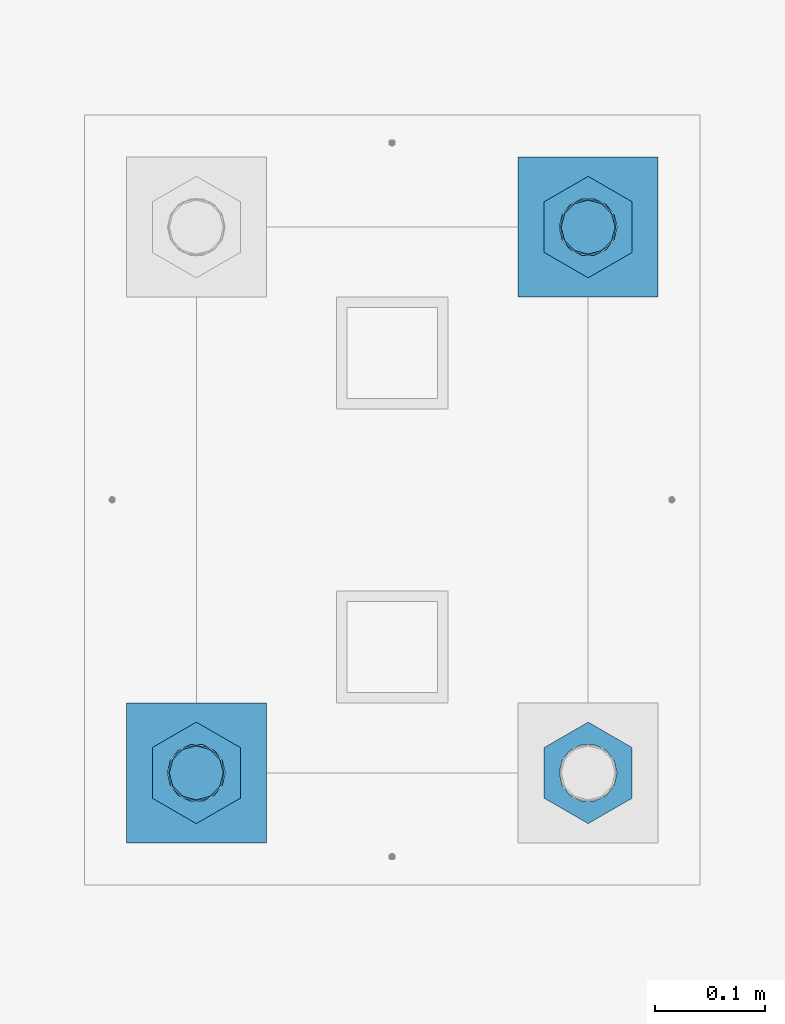
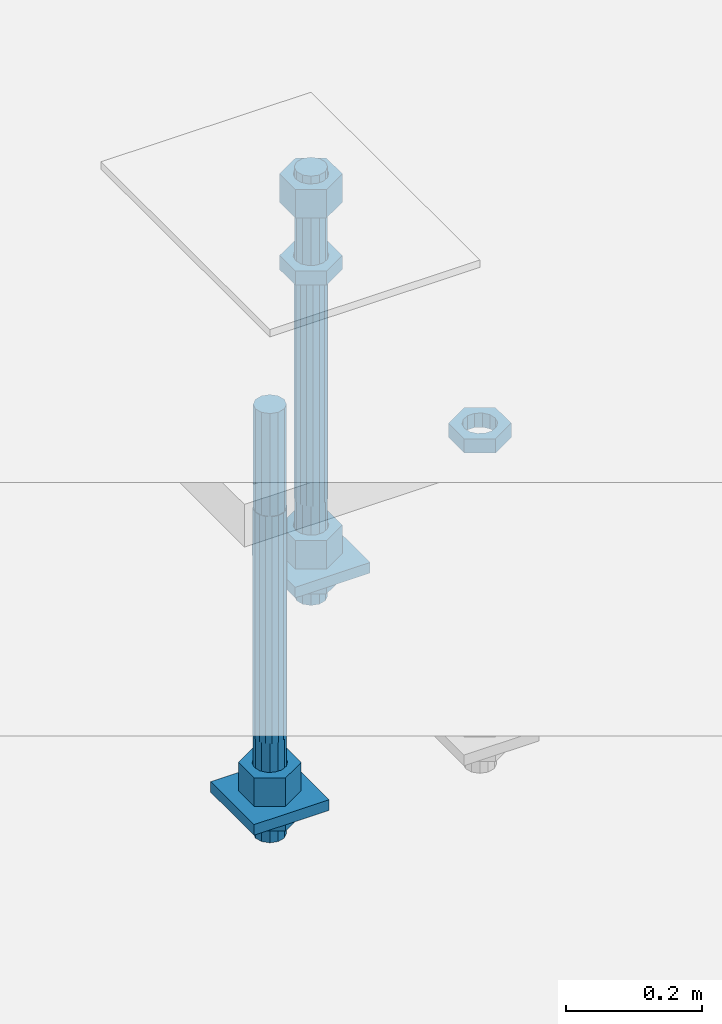
# One storey, part 2562 of 3843: 11 beams, 1 element without a shape of its own.
"""IFC2X3 building model written with IfcOpenShell, lengths in millimetres."""

from ifc_helpers import new_model, si_unit, frame, origin_with_axes, place, context, subcontext, project, spatial, faceted_brep, material, type_object, element, aggregate, save


model = new_model("IFC2X3")

# Units and contexts
model_context = context("Model", 3, precision=1e-05, world=origin_with_axes())
body_context = subcontext(model_context, "Body", "Model", "MODEL_VIEW")
ifc_project = project(units=[si_unit("LENGTHUNIT", "METRE", prefix="MILLI"), si_unit("AREAUNIT", "SQUARE_METRE"), si_unit("VOLUMEUNIT", "CUBIC_METRE"), si_unit("MASSUNIT", "GRAM", prefix="KILO"), si_unit("TIMEUNIT", "SECOND"), si_unit("PLANEANGLEUNIT", "RADIAN"), si_unit("SOLIDANGLEUNIT", "STERADIAN"), si_unit("THERMODYNAMICTEMPERATUREUNIT", "DEGREE_CELSIUS"), si_unit("LUMINOUSINTENSITYUNIT", "LUMEN")], contexts=[model_context])

# Site, building, storey
site_placement = place(None, origin_with_axes())
site = spatial("IfcSite", under=ifc_project, at=site_placement, CompositionType="ELEMENT")
building_placement = place(site_placement, origin_with_axes())
building = spatial("IfcBuilding", under=site, at=building_placement, Name="Undefined", CompositionType="ELEMENT")
storey_placement = place(building_placement, origin_with_axes())
storey = spatial("IfcBuildingStorey", under=building, at=storey_placement, Name="Undefined", CompositionType="ELEMENT", Elevation=0.0)

# Assembly, beams
assembly_placement = place(storey_placement, origin_with_axes())
assembly = element("IfcElementAssembly", 1, at=assembly_placement, inside=storey, Name="TEMPLATE", AssemblyPlace="NOTDEFINED", PredefinedType="RIGID_FRAME")
ifc_material_1 = material(Name="STEEL/A572-50")
beam_type_1 = type_object("IfcBeamType", PredefinedType="NOTDEFINED")
beam_1_placement = place(assembly_placement, frame((108813.600001526, -247.649999999994, 29244.925), z_axis=(0.0, -1.0, 0.0), x_axis=(1.0, 0.0, 0.0)))
beam_1 = element("IfcBeam", 2, at=beam_1_placement, type_object=beam_type_1, material=ifc_material_1, Name="WASHER_PLATE", context=body_context, shape_type="Brep", body=[
    faceted_brep([(0.0, 9.52500000000146, -63.5), (0.0, 9.52500000000146, 63.5), (127.0, 9.52500000000146, 63.5), (127.0, 9.52500000000146, -63.5), (0.0, -9.52500000000146, 63.5), (127.0, -9.52500000000146, 63.5), (0.0, -9.52500000000146, -63.5), (127.0, -9.52500000000146, -63.5)], [[[0, 1, 2, 3]], [[1, 4, 5, 2]], [[4, 6, 7, 5]], [[6, 0, 3, 7]], [[5, 7, 3, 2]], [[6, 4, 1, 0]]]),
])
beam_2_placement = place(assembly_placement, frame((109169.200001526, 247.649999999994, 29244.925), z_axis=(0.0, -1.0, 0.0), x_axis=(1.0, 0.0, 0.0)))
beam_2 = element("IfcBeam", 3, at=beam_2_placement, type_object=beam_type_1, material=ifc_material_1, Name="WASHER_PLATE", context=body_context, shape_type="Brep", body=[
    faceted_brep([(0.0, 9.52500000000146, -63.5), (0.0, 9.52500000000146, 63.5), (127.0, 9.52500000000146, 63.5), (127.0, 9.52500000000146, -63.5), (0.0, -9.52500000000146, 63.5), (127.0, -9.52500000000146, 63.5), (0.0, -9.52500000000146, -63.5), (127.0, -9.52500000000146, -63.5)], [[[0, 1, 2, 3]], [[1, 4, 5, 2]], [[4, 6, 7, 5]], [[6, 0, 3, 7]], [[5, 7, 3, 2]], [[6, 4, 1, 0]]]),
])
ifc_material_2 = material(Name="STEEL/A36")
beam_type_2 = type_object("IfcBeamType", Name="2_HALF_NUT", PredefinedType="NOTDEFINED")
beam_3_placement = place(assembly_placement, frame((108877.100001526, -247.649999999994, 29235.4), z_axis=(1.0, 0.0, 0.0), x_axis=(0.0, 0.0, -1.0)))
beam_3 = element("IfcBeam", 4, at=beam_3_placement, type_object=beam_type_2, material=ifc_material_2, Name="NUT", ObjectType="2_HALF_NUT", context=body_context, shape_type="Brep", body=[
    faceted_brep([(0.0, -46.0369987487793, 0.0), (0.0, -23.0184993743896, -39.869213104248), (25.4000000000015, -23.0184993743896, -39.869213104248), (25.4000000000015, -46.0369987487793, 0.0), (0.0, 23.0184993743896, -39.869213104248), (25.4000000000015, 23.0184993743896, -39.869213104248), (0.0, 46.0369987487793, 0.0), (25.4000000000015, 46.0369987487793, 0.0), (0.0, 23.0184993743896, 39.869213104248), (25.4000000000015, 23.0184993743896, 39.869213104248), (0.0, -23.0184993743896, 39.869213104248), (25.4000000000015, -23.0184993743896, 39.869213104248), (0.0, 0.0, 26.1940002441406), (0.0, 11.3650617044477, 23.5999013092805), (25.4000000000015, 11.3650617044477, 23.5999013092805), (25.4000000000015, 0.0, 26.1940002441406), (0.0, 20.4791109456419, 16.3316083006721), (25.4000000000015, 20.4791109456419, 16.3316083006721), (0.0, 25.5370200498292, 5.82867859874386), (25.4000000000015, 25.5370200498292, 5.82867859874386), (0.0, 25.5370200498292, -5.82867859874386), (25.4000000000015, 25.5370200498292, -5.82867859874386), (0.0, 20.4791109456419, -16.3316083006721), (25.4000000000015, 20.4791109456419, -16.3316083006721), (0.0, 11.3650617044477, -23.5999013092805), (25.4000000000015, 11.3650617044477, -23.5999013092805), (0.0, 0.0, -26.1940002441406), (25.4000000000015, 0.0, -26.1940002441406), (0.0, -11.3650617044477, -23.5999013092805), (25.4000000000015, -11.3650617044477, -23.5999013092805), (0.0, -20.4791109456419, -16.3316083006721), (25.4000000000015, -20.4791109456419, -16.3316083006721), (0.0, -25.5370200498292, -5.82867859874386), (25.4000000000015, -25.5370200498292, -5.82867859874386), (0.0, -25.5370200498292, 5.82867859874386), (25.4000000000015, -25.5370200498292, 5.82867859874386), (0.0, -20.4791109456419, 16.3316083006721), (25.4000000000015, -20.4791109456419, 16.3316083006721), (0.0, -11.3650617044477, 23.5999013092805), (25.4000000000015, -11.3650617044477, 23.5999013092805)], [[[0, 1, 2, 3]], [[1, 4, 5, 2]], [[4, 6, 7, 5]], [[6, 8, 9, 7]], [[8, 10, 11, 9]], [[10, 0, 3, 11]], [[12, 13, 14, 15]], [[13, 16, 17, 14]], [[16, 18, 19, 17]], [[18, 20, 21, 19]], [[20, 22, 23, 21]], [[22, 24, 25, 23]], [[24, 26, 27, 25]], [[26, 28, 29, 27]], [[28, 30, 31, 29]], [[30, 32, 33, 31]], [[32, 34, 35, 33]], [[34, 36, 37, 35]], [[36, 38, 39, 37]], [[38, 12, 15, 39]], [[5, 7, 9, 11, 3, 2], [17, 19, 21, 23, 25, 27, 29, 31, 33, 35, 37, 39, 15, 14]], [[10, 8, 6, 4, 1, 0], [38, 36, 34, 32, 30, 28, 26, 24, 22, 20, 18, 16, 13, 12]]]),
])
beam_4_placement = place(assembly_placement, frame((109232.700001526, 247.649999999994, 29787.85), z_axis=(1.0, 0.0, 0.0), x_axis=(0.0, 0.0, -1.0)))
beam_4 = element("IfcBeam", 5, at=beam_4_placement, type_object=beam_type_2, material=ifc_material_2, Name="NUT", ObjectType="2_HALF_NUT", context=body_context, shape_type="Brep", body=[
    faceted_brep([(0.0, -46.0369987487793, 0.0), (0.0, -23.0184993743896, -39.869213104248), (25.4000000000015, -23.0184993743896, -39.869213104248), (25.4000000000015, -46.0369987487793, 0.0), (0.0, 23.0184993743896, -39.869213104248), (25.4000000000015, 23.0184993743896, -39.869213104248), (0.0, 46.0369987487793, 0.0), (25.4000000000015, 46.0369987487793, 0.0), (0.0, 23.0184993743896, 39.869213104248), (25.4000000000015, 23.0184993743896, 39.869213104248), (0.0, -23.0184993743896, 39.869213104248), (25.4000000000015, -23.0184993743896, 39.869213104248), (0.0, 0.0, 26.1940002441406), (0.0, 11.3650617044477, 23.5999013092805), (25.4000000000015, 11.3650617044477, 23.5999013092805), (25.4000000000015, 0.0, 26.1940002441406), (0.0, 20.4791109456419, 16.3316083006721), (25.4000000000015, 20.4791109456419, 16.3316083006721), (0.0, 25.5370200498292, 5.82867859874386), (25.4000000000015, 25.5370200498292, 5.82867859874386), (0.0, 25.5370200498292, -5.82867859874386), (25.4000000000015, 25.5370200498292, -5.82867859874386), (0.0, 20.4791109456419, -16.3316083006721), (25.4000000000015, 20.4791109456419, -16.3316083006721), (0.0, 11.3650617044477, -23.5999013092805), (25.4000000000015, 11.3650617044477, -23.5999013092805), (0.0, 0.0, -26.1940002441406), (25.4000000000015, 0.0, -26.1940002441406), (0.0, -11.3650617044477, -23.5999013092805), (25.4000000000015, -11.3650617044477, -23.5999013092805), (0.0, -20.4791109456419, -16.3316083006721), (25.4000000000015, -20.4791109456419, -16.3316083006721), (0.0, -25.5370200498292, -5.82867859874386), (25.4000000000015, -25.5370200498292, -5.82867859874386), (0.0, -25.5370200498292, 5.82867859874386), (25.4000000000015, -25.5370200498292, 5.82867859874386), (0.0, -20.4791109456419, 16.3316083006721), (25.4000000000015, -20.4791109456419, 16.3316083006721), (0.0, -11.3650617044477, 23.5999013092805), (25.4000000000015, -11.3650617044477, 23.5999013092805)], [[[0, 1, 2, 3]], [[1, 4, 5, 2]], [[4, 6, 7, 5]], [[6, 8, 9, 7]], [[8, 10, 11, 9]], [[10, 0, 3, 11]], [[12, 13, 14, 15]], [[13, 16, 17, 14]], [[16, 18, 19, 17]], [[18, 20, 21, 19]], [[20, 22, 23, 21]], [[22, 24, 25, 23]], [[24, 26, 27, 25]], [[26, 28, 29, 27]], [[28, 30, 31, 29]], [[30, 32, 33, 31]], [[32, 34, 35, 33]], [[34, 36, 37, 35]], [[36, 38, 39, 37]], [[38, 12, 15, 39]], [[5, 7, 9, 11, 3, 2], [17, 19, 21, 23, 25, 27, 29, 31, 33, 35, 37, 39, 15, 14]], [[10, 8, 6, 4, 1, 0], [38, 36, 34, 32, 30, 28, 26, 24, 22, 20, 18, 16, 13, 12]]]),
])
beam_5_placement = place(assembly_placement, frame((109232.700001526, 247.649999999994, 29235.4), z_axis=(1.0, 0.0, 0.0), x_axis=(0.0, 0.0, -1.0)))
beam_5 = element("IfcBeam", 6, at=beam_5_placement, type_object=beam_type_2, material=ifc_material_2, Name="NUT", ObjectType="2_HALF_NUT", context=body_context, shape_type="Brep", body=[
    faceted_brep([(0.0, -46.0369987487793, 0.0), (0.0, -23.0184993743896, -39.869213104248), (25.4000000000015, -23.0184993743896, -39.869213104248), (25.4000000000015, -46.0369987487793, 0.0), (0.0, 23.0184993743896, -39.869213104248), (25.4000000000015, 23.0184993743896, -39.869213104248), (0.0, 46.0369987487793, 0.0), (25.4000000000015, 46.0369987487793, 0.0), (0.0, 23.0184993743896, 39.869213104248), (25.4000000000015, 23.0184993743896, 39.869213104248), (0.0, -23.0184993743896, 39.869213104248), (25.4000000000015, -23.0184993743896, 39.869213104248), (0.0, 0.0, 26.1940002441406), (0.0, 11.3650617044477, 23.5999013092805), (25.4000000000015, 11.3650617044477, 23.5999013092805), (25.4000000000015, 0.0, 26.1940002441406), (0.0, 20.4791109456419, 16.3316083006721), (25.4000000000015, 20.4791109456419, 16.3316083006721), (0.0, 25.5370200498292, 5.82867859874386), (25.4000000000015, 25.5370200498292, 5.82867859874386), (0.0, 25.5370200498292, -5.82867859874386), (25.4000000000015, 25.5370200498292, -5.82867859874386), (0.0, 20.4791109456419, -16.3316083006721), (25.4000000000015, 20.4791109456419, -16.3316083006721), (0.0, 11.3650617044477, -23.5999013092805), (25.4000000000015, 11.3650617044477, -23.5999013092805), (0.0, 0.0, -26.1940002441406), (25.4000000000015, 0.0, -26.1940002441406), (0.0, -11.3650617044477, -23.5999013092805), (25.4000000000015, -11.3650617044477, -23.5999013092805), (0.0, -20.4791109456419, -16.3316083006721), (25.4000000000015, -20.4791109456419, -16.3316083006721), (0.0, -25.5370200498292, -5.82867859874386), (25.4000000000015, -25.5370200498292, -5.82867859874386), (0.0, -25.5370200498292, 5.82867859874386), (25.4000000000015, -25.5370200498292, 5.82867859874386), (0.0, -20.4791109456419, 16.3316083006721), (25.4000000000015, -20.4791109456419, 16.3316083006721), (0.0, -11.3650617044477, 23.5999013092805), (25.4000000000015, -11.3650617044477, 23.5999013092805)], [[[0, 1, 2, 3]], [[1, 4, 5, 2]], [[4, 6, 7, 5]], [[6, 8, 9, 7]], [[8, 10, 11, 9]], [[10, 0, 3, 11]], [[12, 13, 14, 15]], [[13, 16, 17, 14]], [[16, 18, 19, 17]], [[18, 20, 21, 19]], [[20, 22, 23, 21]], [[22, 24, 25, 23]], [[24, 26, 27, 25]], [[26, 28, 29, 27]], [[28, 30, 31, 29]], [[30, 32, 33, 31]], [[32, 34, 35, 33]], [[34, 36, 37, 35]], [[36, 38, 39, 37]], [[38, 12, 15, 39]], [[5, 7, 9, 11, 3, 2], [17, 19, 21, 23, 25, 27, 29, 31, 33, 35, 37, 39, 15, 14]], [[10, 8, 6, 4, 1, 0], [38, 36, 34, 32, 30, 28, 26, 24, 22, 20, 18, 16, 13, 12]]]),
])
beam_6_placement = place(assembly_placement, frame((109232.700001526, -247.649999999994, 29787.85), z_axis=(1.0, 0.0, 0.0), x_axis=(0.0, 0.0, -1.0)))
beam_6 = element("IfcBeam", 7, at=beam_6_placement, type_object=beam_type_2, material=ifc_material_2, Name="NUT", ObjectType="2_HALF_NUT", context=body_context, shape_type="Brep", body=[
    faceted_brep([(0.0, -46.0369987487793, 0.0), (0.0, -23.0184993743896, -39.869213104248), (25.4000000000015, -23.0184993743896, -39.869213104248), (25.4000000000015, -46.0369987487793, 0.0), (0.0, 23.0184993743896, -39.869213104248), (25.4000000000015, 23.0184993743896, -39.869213104248), (0.0, 46.0369987487793, 0.0), (25.4000000000015, 46.0369987487793, 0.0), (0.0, 23.0184993743896, 39.869213104248), (25.4000000000015, 23.0184993743896, 39.869213104248), (0.0, -23.0184993743896, 39.869213104248), (25.4000000000015, -23.0184993743896, 39.869213104248), (0.0, 0.0, 26.1940002441406), (0.0, 11.3650617044477, 23.5999013092805), (25.4000000000015, 11.3650617044477, 23.5999013092805), (25.4000000000015, 0.0, 26.1940002441406), (0.0, 20.4791109456419, 16.3316083006721), (25.4000000000015, 20.4791109456419, 16.3316083006721), (0.0, 25.5370200498292, 5.82867859874386), (25.4000000000015, 25.5370200498292, 5.82867859874386), (0.0, 25.5370200498292, -5.82867859874386), (25.4000000000015, 25.5370200498292, -5.82867859874386), (0.0, 20.4791109456419, -16.3316083006721), (25.4000000000015, 20.4791109456419, -16.3316083006721), (0.0, 11.3650617044477, -23.5999013092805), (25.4000000000015, 11.3650617044477, -23.5999013092805), (0.0, 0.0, -26.1940002441406), (25.4000000000015, 0.0, -26.1940002441406), (0.0, -11.3650617044477, -23.5999013092805), (25.4000000000015, -11.3650617044477, -23.5999013092805), (0.0, -20.4791109456419, -16.3316083006721), (25.4000000000015, -20.4791109456419, -16.3316083006721), (0.0, -25.5370200498292, -5.82867859874386), (25.4000000000015, -25.5370200498292, -5.82867859874386), (0.0, -25.5370200498292, 5.82867859874386), (25.4000000000015, -25.5370200498292, 5.82867859874386), (0.0, -20.4791109456419, 16.3316083006721), (25.4000000000015, -20.4791109456419, 16.3316083006721), (0.0, -11.3650617044477, 23.5999013092805), (25.4000000000015, -11.3650617044477, 23.5999013092805)], [[[0, 1, 2, 3]], [[1, 4, 5, 2]], [[4, 6, 7, 5]], [[6, 8, 9, 7]], [[8, 10, 11, 9]], [[10, 0, 3, 11]], [[12, 13, 14, 15]], [[13, 16, 17, 14]], [[16, 18, 19, 17]], [[18, 20, 21, 19]], [[20, 22, 23, 21]], [[22, 24, 25, 23]], [[24, 26, 27, 25]], [[26, 28, 29, 27]], [[28, 30, 31, 29]], [[30, 32, 33, 31]], [[32, 34, 35, 33]], [[34, 36, 37, 35]], [[36, 38, 39, 37]], [[38, 12, 15, 39]], [[5, 7, 9, 11, 3, 2], [17, 19, 21, 23, 25, 27, 29, 31, 33, 35, 37, 39, 15, 14]], [[10, 8, 6, 4, 1, 0], [38, 36, 34, 32, 30, 28, 26, 24, 22, 20, 18, 16, 13, 12]]]),
])
beam_type_3 = type_object("IfcBeamType", Name="2_HEAVY_HEX_NUT", PredefinedType="NOTDEFINED")
beam_7_placement = place(assembly_placement, frame((108877.100001526, -247.649999999994, 29305.25), z_axis=(1.0, 0.0, 0.0), x_axis=(0.0, 0.0, -1.0)))
beam_7 = element("IfcBeam", 8, at=beam_7_placement, type_object=beam_type_3, material=ifc_material_2, Name="NUT", ObjectType="2_HEAVY_HEX_NUT", context=body_context, shape_type="Brep", body=[
    faceted_brep([(0.0, -46.0369987487793, 0.0), (0.0, -23.0184993743896, -39.869213104248), (50.7999999999993, -23.0184993743896, -39.869213104248), (50.7999999999993, -46.0369987487793, 0.0), (0.0, 23.0184993743896, -39.869213104248), (50.7999999999993, 23.0184993743896, -39.869213104248), (0.0, 46.0369987487793, 0.0), (50.7999999999993, 46.0369987487793, 0.0), (0.0, 23.0184993743896, 39.869213104248), (50.7999999999993, 23.0184993743896, 39.869213104248), (0.0, -23.0184993743896, 39.869213104248), (50.7999999999993, -23.0184993743896, 39.869213104248), (0.0, 0.0, 26.1940002441406), (0.0, 11.3650617044477, 23.5999013092805), (50.7999999999993, 11.3650617044477, 23.5999013092805), (50.7999999999993, 0.0, 26.1940002441406), (0.0, 20.4791109456419, 16.3316083006721), (50.7999999999993, 20.4791109456419, 16.3316083006721), (0.0, 25.5370200498292, 5.82867859874386), (50.7999999999993, 25.5370200498292, 5.82867859874386), (0.0, 25.5370200498292, -5.82867859874386), (50.7999999999993, 25.5370200498292, -5.82867859874386), (0.0, 20.4791109456419, -16.3316083006721), (50.7999999999993, 20.4791109456419, -16.3316083006721), (0.0, 11.3650617044477, -23.5999013092805), (50.7999999999993, 11.3650617044477, -23.5999013092805), (0.0, 0.0, -26.1940002441406), (50.7999999999993, 0.0, -26.1940002441406), (0.0, -11.3650617044477, -23.5999013092805), (50.7999999999993, -11.3650617044477, -23.5999013092805), (0.0, -20.4791109456419, -16.3316083006721), (50.7999999999993, -20.4791109456419, -16.3316083006721), (0.0, -25.5370200498292, -5.82867859874386), (50.7999999999993, -25.5370200498292, -5.82867859874386), (0.0, -25.5370200498292, 5.82867859874386), (50.7999999999993, -25.5370200498292, 5.82867859874386), (0.0, -20.4791109456419, 16.3316083006721), (50.7999999999993, -20.4791109456419, 16.3316083006721), (0.0, -11.3650617044477, 23.5999013092805), (50.7999999999993, -11.3650617044477, 23.5999013092805)], [[[0, 1, 2, 3]], [[1, 4, 5, 2]], [[4, 6, 7, 5]], [[6, 8, 9, 7]], [[8, 10, 11, 9]], [[10, 0, 3, 11]], [[12, 13, 14, 15]], [[13, 16, 17, 14]], [[16, 18, 19, 17]], [[18, 20, 21, 19]], [[20, 22, 23, 21]], [[22, 24, 25, 23]], [[24, 26, 27, 25]], [[26, 28, 29, 27]], [[28, 30, 31, 29]], [[30, 32, 33, 31]], [[32, 34, 35, 33]], [[34, 36, 37, 35]], [[36, 38, 39, 37]], [[38, 12, 15, 39]], [[5, 7, 9, 11, 3, 2], [17, 19, 21, 23, 25, 27, 29, 31, 33, 35, 37, 39, 15, 14]], [[10, 8, 6, 4, 1, 0], [38, 36, 34, 32, 30, 28, 26, 24, 22, 20, 18, 16, 13, 12]]]),
])
beam_8_placement = place(assembly_placement, frame((109232.700001526, 247.649999999994, 29933.9), z_axis=(1.0, 0.0, 0.0), x_axis=(0.0, 0.0, -1.0)))
beam_8 = element("IfcBeam", 9, at=beam_8_placement, type_object=beam_type_3, material=ifc_material_2, Name="NUT", ObjectType="2_HEAVY_HEX_NUT", context=body_context, shape_type="Brep", body=[
    faceted_brep([(0.0, -46.0369987487793, 0.0), (0.0, -23.0184993743896, -39.869213104248), (50.7999999999993, -23.0184993743896, -39.869213104248), (50.7999999999993, -46.0369987487793, 0.0), (0.0, 23.0184993743896, -39.869213104248), (50.7999999999993, 23.0184993743896, -39.869213104248), (0.0, 46.0369987487793, 0.0), (50.7999999999993, 46.0369987487793, 0.0), (0.0, 23.0184993743896, 39.869213104248), (50.7999999999993, 23.0184993743896, 39.869213104248), (0.0, -23.0184993743896, 39.869213104248), (50.7999999999993, -23.0184993743896, 39.869213104248), (0.0, 0.0, 26.1940002441406), (0.0, 11.3650617044477, 23.5999013092805), (50.7999999999993, 11.3650617044477, 23.5999013092805), (50.7999999999993, 0.0, 26.1940002441406), (0.0, 20.4791109456419, 16.3316083006721), (50.7999999999993, 20.4791109456419, 16.3316083006721), (0.0, 25.5370200498292, 5.82867859874386), (50.7999999999993, 25.5370200498292, 5.82867859874386), (0.0, 25.5370200498292, -5.82867859874386), (50.7999999999993, 25.5370200498292, -5.82867859874386), (0.0, 20.4791109456419, -16.3316083006721), (50.7999999999993, 20.4791109456419, -16.3316083006721), (0.0, 11.3650617044477, -23.5999013092805), (50.7999999999993, 11.3650617044477, -23.5999013092805), (0.0, 0.0, -26.1940002441406), (50.7999999999993, 0.0, -26.1940002441406), (0.0, -11.3650617044477, -23.5999013092805), (50.7999999999993, -11.3650617044477, -23.5999013092805), (0.0, -20.4791109456419, -16.3316083006721), (50.7999999999993, -20.4791109456419, -16.3316083006721), (0.0, -25.5370200498292, -5.82867859874386), (50.7999999999993, -25.5370200498292, -5.82867859874386), (0.0, -25.5370200498292, 5.82867859874386), (50.7999999999993, -25.5370200498292, 5.82867859874386), (0.0, -20.4791109456419, 16.3316083006721), (50.7999999999993, -20.4791109456419, 16.3316083006721), (0.0, -11.3650617044477, 23.5999013092805), (50.7999999999993, -11.3650617044477, 23.5999013092805)], [[[0, 1, 2, 3]], [[1, 4, 5, 2]], [[4, 6, 7, 5]], [[6, 8, 9, 7]], [[8, 10, 11, 9]], [[10, 0, 3, 11]], [[12, 13, 14, 15]], [[13, 16, 17, 14]], [[16, 18, 19, 17]], [[18, 20, 21, 19]], [[20, 22, 23, 21]], [[22, 24, 25, 23]], [[24, 26, 27, 25]], [[26, 28, 29, 27]], [[28, 30, 31, 29]], [[30, 32, 33, 31]], [[32, 34, 35, 33]], [[34, 36, 37, 35]], [[36, 38, 39, 37]], [[38, 12, 15, 39]], [[5, 7, 9, 11, 3, 2], [17, 19, 21, 23, 25, 27, 29, 31, 33, 35, 37, 39, 15, 14]], [[10, 8, 6, 4, 1, 0], [38, 36, 34, 32, 30, 28, 26, 24, 22, 20, 18, 16, 13, 12]]]),
])
beam_9_placement = place(assembly_placement, frame((109232.700001526, 247.649999999994, 29305.25), z_axis=(1.0, 0.0, 0.0), x_axis=(0.0, 0.0, -1.0)))
beam_9 = element("IfcBeam", 10, at=beam_9_placement, type_object=beam_type_3, material=ifc_material_2, Name="NUT", ObjectType="2_HEAVY_HEX_NUT", context=body_context, shape_type="Brep", body=[
    faceted_brep([(0.0, -46.0369987487793, 0.0), (0.0, -23.0184993743896, -39.869213104248), (50.7999999999993, -23.0184993743896, -39.869213104248), (50.7999999999993, -46.0369987487793, 0.0), (0.0, 23.0184993743896, -39.869213104248), (50.7999999999993, 23.0184993743896, -39.869213104248), (0.0, 46.0369987487793, 0.0), (50.7999999999993, 46.0369987487793, 0.0), (0.0, 23.0184993743896, 39.869213104248), (50.7999999999993, 23.0184993743896, 39.869213104248), (0.0, -23.0184993743896, 39.869213104248), (50.7999999999993, -23.0184993743896, 39.869213104248), (0.0, 0.0, 26.1940002441406), (0.0, 11.3650617044477, 23.5999013092805), (50.7999999999993, 11.3650617044477, 23.5999013092805), (50.7999999999993, 0.0, 26.1940002441406), (0.0, 20.4791109456419, 16.3316083006721), (50.7999999999993, 20.4791109456419, 16.3316083006721), (0.0, 25.5370200498292, 5.82867859874386), (50.7999999999993, 25.5370200498292, 5.82867859874386), (0.0, 25.5370200498292, -5.82867859874386), (50.7999999999993, 25.5370200498292, -5.82867859874386), (0.0, 20.4791109456419, -16.3316083006721), (50.7999999999993, 20.4791109456419, -16.3316083006721), (0.0, 11.3650617044477, -23.5999013092805), (50.7999999999993, 11.3650617044477, -23.5999013092805), (0.0, 0.0, -26.1940002441406), (50.7999999999993, 0.0, -26.1940002441406), (0.0, -11.3650617044477, -23.5999013092805), (50.7999999999993, -11.3650617044477, -23.5999013092805), (0.0, -20.4791109456419, -16.3316083006721), (50.7999999999993, -20.4791109456419, -16.3316083006721), (0.0, -25.5370200498292, -5.82867859874386), (50.7999999999993, -25.5370200498292, -5.82867859874386), (0.0, -25.5370200498292, 5.82867859874386), (50.7999999999993, -25.5370200498292, 5.82867859874386), (0.0, -20.4791109456419, 16.3316083006721), (50.7999999999993, -20.4791109456419, 16.3316083006721), (0.0, -11.3650617044477, 23.5999013092805), (50.7999999999993, -11.3650617044477, 23.5999013092805)], [[[0, 1, 2, 3]], [[1, 4, 5, 2]], [[4, 6, 7, 5]], [[6, 8, 9, 7]], [[8, 10, 11, 9]], [[10, 0, 3, 11]], [[12, 13, 14, 15]], [[13, 16, 17, 14]], [[16, 18, 19, 17]], [[18, 20, 21, 19]], [[20, 22, 23, 21]], [[22, 24, 25, 23]], [[24, 26, 27, 25]], [[26, 28, 29, 27]], [[28, 30, 31, 29]], [[30, 32, 33, 31]], [[32, 34, 35, 33]], [[34, 36, 37, 35]], [[36, 38, 39, 37]], [[38, 12, 15, 39]], [[5, 7, 9, 11, 3, 2], [17, 19, 21, 23, 25, 27, 29, 31, 33, 35, 37, 39, 15, 14]], [[10, 8, 6, 4, 1, 0], [38, 36, 34, 32, 30, 28, 26, 24, 22, 20, 18, 16, 13, 12]]]),
])
ifc_material_3 = material()
beam_type_4 = type_object("IfcBeamType", PredefinedType="NOTDEFINED")
beam_10_placement = place(assembly_placement, frame((108877.100001526, -247.649999999994, 29762.45), z_axis=(1.0, 0.0, 0.0), x_axis=(0.0, 0.0, -1.0)))
beam_10 = element("IfcBeam", 11, at=beam_10_placement, type_object=beam_type_4, material=ifc_material_3, Name="ANCHOR_ROD", context=body_context, shape_type="Brep", body=[
    faceted_brep([(-184.150000000001, -21.217622392709, 12.25), (-184.150000000001, -12.2499999999854, 21.2176223927163), (-184.150000000001, 1.45519152283669e-11, 24.5), (-184.150000000001, 12.2500000000146, 21.2176223927163), (-184.150000000001, 21.2176223927381, 12.25), (-184.150000000001, 24.5000000000146, 0.0), (-184.150000000001, 21.2176223927381, -12.25), (-184.150000000001, 12.2500000000146, -21.2176223927163), (-184.150000000001, 1.45519152283669e-11, -24.5), (-184.150000000001, -12.2499999999854, -21.2176223927163), (-184.150000000001, -21.217622392709, -12.25), (-184.150000000001, -24.4999999999854, 0.0), (0.0, 24.5000000000146, 0.0), (0.0, 21.2176223927381, -12.25), (0.0, 12.2500000000146, -21.2176223927163), (0.0, 1.45519152283669e-11, -24.5), (0.0, -12.2499999999854, -21.2176223927163), (0.0, -21.217622392709, -12.25), (0.0, -24.4999999999854, 0.0), (0.0, -21.217622392709, 12.25), (0.0, -12.2499999999854, 21.2176223927163), (0.0, 1.45519152283669e-11, 24.5), (0.0, 12.2500000000146, 21.2176223927163), (0.0, 21.2176223927381, 12.25), (0.0, -23.4665401257807, 9.72015918207035), (0.0, -17.9605122421344, 17.9605122421417), (0.0, -9.72015918207762, 23.466540125788), (0.0, 0.0, 25.4000000000015), (0.0, 9.72015918207762, 23.466540125788), (0.0, 17.9605122421344, 17.9605122421417), (0.0, 23.4665401257807, 9.72015918207035), (0.0, 25.3999996185303, 0.0), (0.0, 23.4665401257807, -9.72015918207035), (0.0, 17.9605122421344, -17.9605122421417), (0.0, 9.72015918207762, -23.466540125788), (0.0, 0.0, -25.4000000000015), (0.0, -9.72015918207762, -23.466540125788), (0.0, -17.9605122421344, -17.9605122421417), (0.0, -23.4665401257807, -9.72015918207035), (0.0, -25.3999996185303, 0.0), (406.399999999998, -25.3999999999942, 0.0), (406.399999999998, -23.4665401257807, 9.72015918207035), (406.399999999998, -17.9605122421344, 17.9605122421417), (406.399999999998, -9.72015918207762, 23.466540125788), (406.399999999998, 0.0, 25.4000000000015), (406.399999999998, 9.72015918207762, 23.466540125788), (406.399999999998, 17.9605122421344, 17.9605122421417), (406.399999999998, 23.4665401257807, 9.72015918207035), (406.399999999998, 25.3999999999942, 0.0), (406.399999999998, 23.4665401257807, -9.72015918207035), (406.399999999998, 17.9605122421344, -17.9605122421417), (406.399999999998, 9.72015918207762, -23.466540125788), (406.399999999998, 0.0, -25.4000000000015), (406.399999999998, -9.72015918207762, -23.466540125788), (406.399999999998, -17.9605122421344, -17.9605122421417), (406.399999999998, -23.4665401257807, -9.72015918207035), (406.399999999998, -12.2499999999854, 21.2176223927163), (406.399999999998, 1.45519152283669e-11, 24.5), (406.399999999998, 12.2500000000146, 21.2176223927163), (406.399999999998, 21.2176223927381, 12.25), (406.399999999998, 24.5000000000146, 0.0), (406.399999999998, 21.2176223927381, -12.25), (406.399999999998, 12.2500000000146, -21.2176223927163), (406.399999999998, 1.45519152283669e-11, -24.5), (406.399999999998, -12.2499999999854, -21.2176223927163), (406.399999999998, -21.217622392709, -12.25), (406.399999999998, -24.4999999999854, 0.0), (406.399999999998, -21.217622392709, 12.25), (584.200000000001, -12.2499999999854, -21.2176223927163), (584.200000000001, 1.45519152283669e-11, -24.5), (584.200000000001, 12.2500000000146, -21.2176223927163), (584.200000000001, 21.2176223927381, -12.25), (584.200000000001, 24.5000000000146, 0.0), (584.200000000001, 21.2176223927381, 12.25), (584.200000000001, 12.2500000000146, 21.2176223927163), (584.200000000001, 1.45519152283669e-11, 24.5), (584.200000000001, -12.2499999999854, 21.2176223927163), (584.200000000001, -21.217622392709, 12.25), (584.200000000001, -24.4999999999854, 0.0), (584.200000000001, -21.217622392709, -12.25)], [[[0, 1, 2, 3, 4, 5, 6, 7, 8, 9, 10, 11]], [[6, 5, 12, 13]], [[7, 6, 13, 14]], [[8, 7, 14, 15]], [[9, 8, 15, 16]], [[10, 9, 16, 17]], [[11, 10, 17, 18]], [[0, 11, 18, 19]], [[1, 0, 19, 20]], [[2, 1, 20, 21]], [[3, 2, 21, 22]], [[4, 3, 22, 23]], [[5, 4, 23, 12]], [[24, 25, 26, 27, 28, 29, 30, 31, 32, 33, 34, 35, 36, 37, 38, 39], [22, 21, 20, 19, 18, 17, 16, 15, 14, 13, 12, 23]], [[24, 39, 40, 41]], [[25, 24, 41, 42]], [[26, 25, 42, 43]], [[27, 26, 43, 44]], [[28, 27, 44, 45]], [[29, 28, 45, 46]], [[30, 29, 46, 47]], [[31, 30, 47, 48]], [[32, 31, 48, 49]], [[33, 32, 49, 50]], [[34, 33, 50, 51]], [[35, 34, 51, 52]], [[36, 35, 52, 53]], [[37, 36, 53, 54]], [[38, 37, 54, 55]], [[39, 38, 55, 40]], [[54, 53, 52, 51, 50, 49, 48, 47, 46, 45, 44, 43, 42, 41, 40, 55], [56, 57, 58, 59, 60, 61, 62, 63, 64, 65, 66, 67]], [[68, 69, 70, 71, 72, 73, 74, 75, 76, 77, 78, 79]], [[76, 75, 57, 56]], [[77, 76, 56, 67]], [[78, 77, 67, 66]], [[79, 78, 66, 65]], [[68, 79, 65, 64]], [[69, 68, 64, 63]], [[70, 69, 63, 62]], [[71, 70, 62, 61]], [[72, 71, 61, 60]], [[73, 72, 60, 59]], [[74, 73, 59, 58]], [[75, 74, 58, 57]]]),
])
beam_11_placement = place(assembly_placement, frame((109232.700001526, 247.649999999994, 29762.45), z_axis=(1.0, 0.0, 0.0), x_axis=(0.0, 0.0, -1.0)))
beam_11 = element("IfcBeam", 12, at=beam_11_placement, type_object=beam_type_4, material=ifc_material_3, Name="ANCHOR_ROD", context=body_context, shape_type="Brep", body=[
    faceted_brep([(-184.150000000001, -21.217622392709, 12.25), (-184.150000000001, -12.2499999999854, 21.2176223927163), (-184.150000000001, 1.45519152283669e-11, 24.5), (-184.150000000001, 12.2500000000146, 21.2176223927163), (-184.150000000001, 21.2176223927381, 12.25), (-184.150000000001, 24.5000000000146, 0.0), (-184.150000000001, 21.2176223927381, -12.25), (-184.150000000001, 12.2500000000146, -21.2176223927163), (-184.150000000001, 1.45519152283669e-11, -24.5), (-184.150000000001, -12.2499999999854, -21.2176223927163), (-184.150000000001, -21.217622392709, -12.25), (-184.150000000001, -24.4999999999854, 0.0), (0.0, 24.5000000000146, 0.0), (0.0, 21.2176223927381, -12.25), (0.0, 12.2500000000146, -21.2176223927163), (0.0, 1.45519152283669e-11, -24.5), (0.0, -12.2499999999854, -21.2176223927163), (0.0, -21.217622392709, -12.25), (0.0, -24.4999999999854, 0.0), (0.0, -21.217622392709, 12.25), (0.0, -12.2499999999854, 21.2176223927163), (0.0, 1.45519152283669e-11, 24.5), (0.0, 12.2500000000146, 21.2176223927163), (0.0, 21.2176223927381, 12.25), (0.0, -23.4665401257807, 9.72015918207035), (0.0, -17.9605122421344, 17.9605122421417), (0.0, -9.72015918207762, 23.466540125788), (0.0, 0.0, 25.4000000000015), (0.0, 9.72015918207762, 23.466540125788), (0.0, 17.9605122421344, 17.9605122421417), (0.0, 23.4665401257807, 9.72015918207035), (0.0, 25.3999996185303, 0.0), (0.0, 23.4665401257807, -9.72015918207035), (0.0, 17.9605122421344, -17.9605122421417), (0.0, 9.72015918207762, -23.466540125788), (0.0, 0.0, -25.4000000000015), (0.0, -9.72015918207762, -23.466540125788), (0.0, -17.9605122421344, -17.9605122421417), (0.0, -23.4665401257807, -9.72015918207035), (0.0, -25.3999996185303, 0.0), (406.399999999998, -25.3999999999942, 0.0), (406.399999999998, -23.4665401257807, 9.72015918207035), (406.399999999998, -17.9605122421344, 17.9605122421417), (406.399999999998, -9.72015918207762, 23.466540125788), (406.399999999998, 0.0, 25.4000000000015), (406.399999999998, 9.72015918207762, 23.466540125788), (406.399999999998, 17.9605122421344, 17.9605122421417), (406.399999999998, 23.4665401257807, 9.72015918207035), (406.399999999998, 25.3999999999942, 0.0), (406.399999999998, 23.4665401257807, -9.72015918207035), (406.399999999998, 17.9605122421344, -17.9605122421417), (406.399999999998, 9.72015918207762, -23.466540125788), (406.399999999998, 0.0, -25.4000000000015), (406.399999999998, -9.72015918207762, -23.466540125788), (406.399999999998, -17.9605122421344, -17.9605122421417), (406.399999999998, -23.4665401257807, -9.72015918207035), (406.399999999998, -12.2499999999854, 21.2176223927163), (406.399999999998, 1.45519152283669e-11, 24.5), (406.399999999998, 12.2500000000146, 21.2176223927163), (406.399999999998, 21.2176223927381, 12.25), (406.399999999998, 24.5000000000146, 0.0), (406.399999999998, 21.2176223927381, -12.25), (406.399999999998, 12.2500000000146, -21.2176223927163), (406.399999999998, 1.45519152283669e-11, -24.5), (406.399999999998, -12.2499999999854, -21.2176223927163), (406.399999999998, -21.217622392709, -12.25), (406.399999999998, -24.4999999999854, 0.0), (406.399999999998, -21.217622392709, 12.25), (584.200000000001, -12.2499999999854, -21.2176223927163), (584.200000000001, 1.45519152283669e-11, -24.5), (584.200000000001, 12.2500000000146, -21.2176223927163), (584.200000000001, 21.2176223927381, -12.25), (584.200000000001, 24.5000000000146, 0.0), (584.200000000001, 21.2176223927381, 12.25), (584.200000000001, 12.2500000000146, 21.2176223927163), (584.200000000001, 1.45519152283669e-11, 24.5), (584.200000000001, -12.2499999999854, 21.2176223927163), (584.200000000001, -21.217622392709, 12.25), (584.200000000001, -24.4999999999854, 0.0), (584.200000000001, -21.217622392709, -12.25)], [[[0, 1, 2, 3, 4, 5, 6, 7, 8, 9, 10, 11]], [[6, 5, 12, 13]], [[7, 6, 13, 14]], [[8, 7, 14, 15]], [[9, 8, 15, 16]], [[10, 9, 16, 17]], [[11, 10, 17, 18]], [[0, 11, 18, 19]], [[1, 0, 19, 20]], [[2, 1, 20, 21]], [[3, 2, 21, 22]], [[4, 3, 22, 23]], [[5, 4, 23, 12]], [[24, 25, 26, 27, 28, 29, 30, 31, 32, 33, 34, 35, 36, 37, 38, 39], [22, 21, 20, 19, 18, 17, 16, 15, 14, 13, 12, 23]], [[24, 39, 40, 41]], [[25, 24, 41, 42]], [[26, 25, 42, 43]], [[27, 26, 43, 44]], [[28, 27, 44, 45]], [[29, 28, 45, 46]], [[30, 29, 46, 47]], [[31, 30, 47, 48]], [[32, 31, 48, 49]], [[33, 32, 49, 50]], [[34, 33, 50, 51]], [[35, 34, 51, 52]], [[36, 35, 52, 53]], [[37, 36, 53, 54]], [[38, 37, 54, 55]], [[39, 38, 55, 40]], [[54, 53, 52, 51, 50, 49, 48, 47, 46, 45, 44, 43, 42, 41, 40, 55], [56, 57, 58, 59, 60, 61, 62, 63, 64, 65, 66, 67]], [[68, 69, 70, 71, 72, 73, 74, 75, 76, 77, 78, 79]], [[76, 75, 57, 56]], [[77, 76, 56, 67]], [[78, 77, 67, 66]], [[79, 78, 66, 65]], [[68, 79, 65, 64]], [[69, 68, 64, 63]], [[70, 69, 63, 62]], [[71, 70, 62, 61]], [[72, 71, 61, 60]], [[73, 72, 60, 59]], [[74, 73, 59, 58]], [[75, 74, 58, 57]]]),
])
aggregate(assembly, [beam_7, beam_3, beam_1, beam_10, beam_4, beam_8, beam_9, beam_5, beam_2, beam_11, beam_6])

save(model, "model.ifc")
